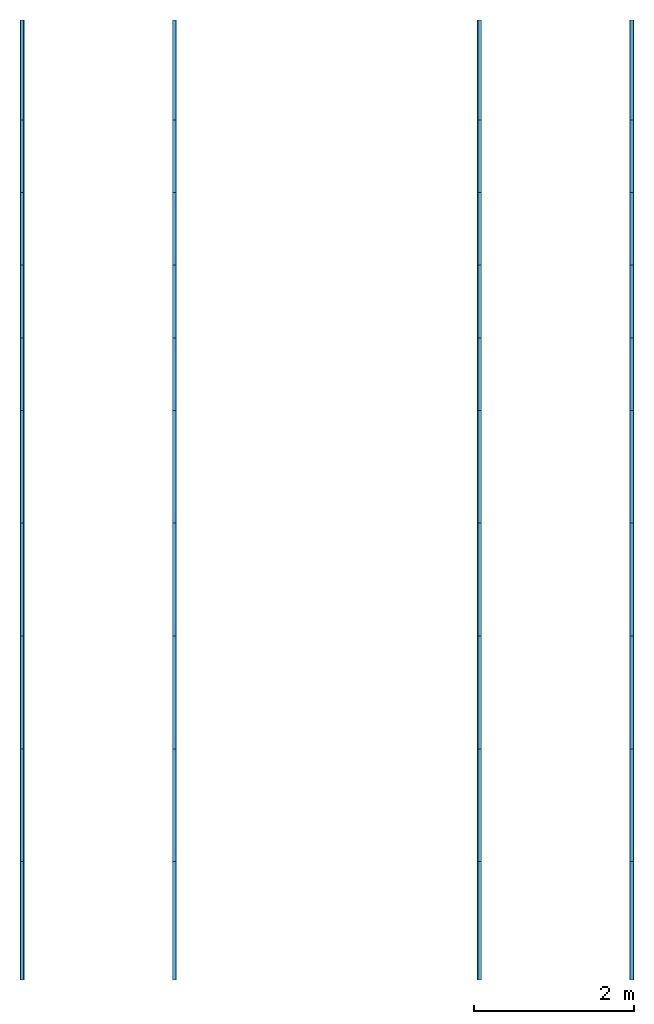
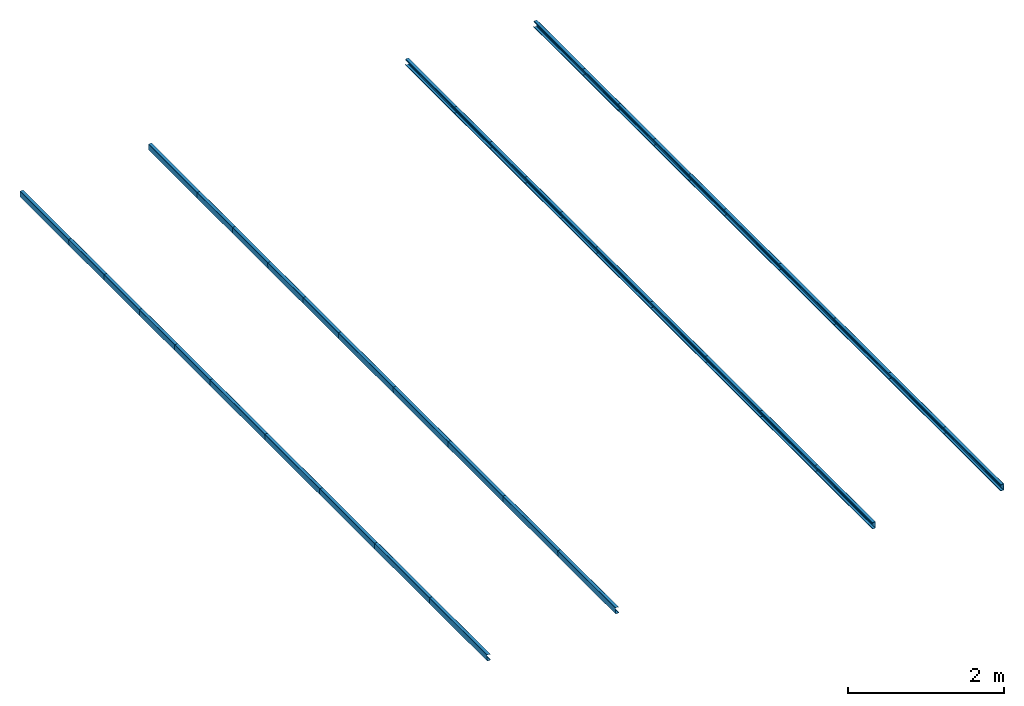
# One storey: 40 beams.
"""IFC4 building model written with IfcOpenShell, lengths in metres."""

import ifcopenshell
import ifcopenshell.guid

model = None  # the IFC model being written
_history = None  # IfcOwnerHistory: only IFC2X3 demands one
_inside = {}  # id of a spatial element -> (the spatial element, [elements in it])
_under = {}  # id of a project, library or spatial element -> (it, [spatial elements below it])
_declared = {}  # id of a project -> (the project, [libraries it declares])
_typed = {}  # id of a type object -> (the type object, [elements of that type])
_made_of = {}  # id of a material, layer set ... -> (it, [elements and type objects made of it])


def new_model(schema):
    """Start an empty IFC model of exactly this schema.

    Asked for "IFC4X3", IfcOpenShell would pick the latest addendum, in which some entities
    have other attributes; the version numbers below select the first issue.
    IFC2X3 requires an IfcOwnerHistory on every rooted entity: one is made here for all.
    """
    global model, _history
    if schema == "IFC4X3":
        model = ifcopenshell.file(schema_version=(4, 3, 0, 0))
    else:
        model = ifcopenshell.file(schema=schema)
    _inside.clear()
    _under.clear()
    _declared.clear()
    _typed.clear()
    _made_of.clear()
    _history = None
    if model.schema == "IFC2X3":
        org = make("IfcOrganization", Name="unknown")
        user = make(
            "IfcPersonAndOrganization",
            ThePerson=make("IfcPerson", FamilyName="unknown"),
            TheOrganization=org,
        )
        app = make(
            "IfcApplication",
            ApplicationDeveloper=org,
            Version="unknown",
            ApplicationFullName="unknown",
            ApplicationIdentifier="unknown",
        )
        _history = make(
            "IfcOwnerHistory",
            OwningUser=user,
            OwningApplication=app,
            ChangeAction="ADDED",
            CreationDate=0,
        )
    return model


def make(cls, **values):
    """One entity of the class cls with the attributes given. An attribute that is None is left unset."""
    return model.create_entity(
        cls, **{name: value for name, value in values.items() if value is not None}
    )


def rooted(cls, **values):
    """An entity with a GlobalId (a new one), such as an element, a storey or a relation."""
    return make(cls, GlobalId=ifcopenshell.guid.new(), OwnerHistory=_history, **values)


def si_unit(unit_type, name, prefix=None):
    """IfcSIUnit, for example si_unit("LENGTHUNIT", "METRE", prefix="MILLI")."""
    return make("IfcSIUnit", UnitType=unit_type, Prefix=prefix, Name=name)


def derived_unit(unit_type, elements):
    """IfcDerivedUnit: a product of units, each with its exponent."""
    return make(
        "IfcDerivedUnit",
        Elements=[
            make("IfcDerivedUnitElement", Unit=unit, Exponent=power)
            for unit, power in elements
        ],
        UnitType=unit_type,
    )


def assignment(units):
    """IfcUnitAssignment: the units of a project."""
    return None if units is None else make("IfcUnitAssignment", Units=units)


def point(xyz):
    """IfcCartesianPoint."""
    return None if xyz is None else make("IfcCartesianPoint", Coordinates=xyz)


def direction(xyz):
    """IfcDirection."""
    return None if xyz is None else make("IfcDirection", DirectionRatios=xyz)


def frame(location, z_axis=None, x_axis=None):
    """IfcAxis2Placement3D, a coordinate frame: its origin and axes. An axis left out is left unset."""
    return make(
        "IfcAxis2Placement3D",
        Location=point(location),
        Axis=direction(z_axis),
        RefDirection=direction(x_axis),
    )


def frame_2d(location, x_axis=None):
    """IfcAxis2Placement2D, a coordinate frame in the plane: its origin and x axis."""
    return make(
        "IfcAxis2Placement2D", Location=point(location), RefDirection=direction(x_axis)
    )


def origin_with_axes():
    """The frame at (0, 0, 0) with the z axis (0, 0, 1) and the x axis (1, 0, 0) written out."""
    return frame((0.0, 0.0, 0.0), z_axis=(0.0, 0.0, 1.0), x_axis=(1.0, 0.0, 0.0))


def origin_2d_with_axis():
    """The frame at (0, 0) in the plane with the x axis (1, 0) written out."""
    return frame_2d((0.0, 0.0), x_axis=(1.0, 0.0))


def place(relative_to, where):
    """IfcLocalPlacement: puts the frame where relative to a parent placement (None: the world)."""
    return make(
        "IfcLocalPlacement", PlacementRelTo=relative_to, RelativePlacement=where
    )


def context(
    kind, dimensions, precision=None, world=None, true_north=None, identifier=None
):
    """IfcGeometricRepresentationContext, for example the 3D "Model" context."""
    return make(
        "IfcGeometricRepresentationContext",
        ContextIdentifier=identifier,
        ContextType=kind,
        CoordinateSpaceDimension=dimensions,
        Precision=precision,
        WorldCoordinateSystem=world,
        TrueNorth=true_north,
    )


def project(units=None, contexts=None):
    """IfcProject with its units and contexts."""
    return rooted(
        "IfcProject",
        Name="project",
        RepresentationContexts=contexts,
        UnitsInContext=assignment(units),
    )


def spatial(cls, under=None, at=None, **own):
    """A site, building, storey or space (cls), placed at a placement, below another one or the project."""
    s = rooted(cls, ObjectPlacement=at, **own)
    if under is not None:
        _under.setdefault(under.id(), (under, []))[1].append(s)
    return s


def profile(cls, at=None, kind="AREA", **sizes):
    """A parametric profile (cls). Its sizes go by their IFC names, for example OverallWidth=200.0."""
    return make(cls, ProfileType=kind, Position=at, **sizes)


def c_section(**sizes):
    """IfcCShapeProfileDef."""
    return profile("IfcCShapeProfileDef", **sizes)


def extrude(swept, where, along, depth):
    """IfcExtrudedAreaSolid: the profile swept, set in the frame where, extruded along a direction by depth."""
    return make(
        "IfcExtrudedAreaSolid",
        SweptArea=swept,
        Position=where,
        ExtrudedDirection=direction(along),
        Depth=depth,
    )


def shape(context_of_items, identifier, shape_type, items):
    """IfcShapeRepresentation: the items that make up one representation, for example the "Body"."""
    return make(
        "IfcShapeRepresentation",
        ContextOfItems=context_of_items,
        RepresentationIdentifier=identifier,
        RepresentationType=shape_type,
        Items=items,
    )


def material(Name=None, Category=None):
    """IfcMaterial."""
    return make("IfcMaterial", Name=Name, Category=Category)


def material_profile(
    of_material, cross_section, Name=None, Category=None, Priority=None
):
    """IfcMaterialProfile: a cross section and its material."""
    return make(
        "IfcMaterialProfile",
        Name=Name,
        Material=of_material,
        Profile=cross_section,
        Priority=Priority,
        Category=Category,
    )


def profile_set(profiles, Name=None, composite=None):
    """IfcMaterialProfileSet."""
    return make(
        "IfcMaterialProfileSet",
        Name=Name,
        MaterialProfiles=profiles,
        CompositeProfile=composite,
    )


def profile_usage(for_profile_set, cardinal=None, extent=None):
    """IfcMaterialProfileSetUsage: how a profile set lies along its element."""
    return make(
        "IfcMaterialProfileSetUsage",
        ForProfileSet=for_profile_set,
        CardinalPoint=cardinal,
        ReferenceExtent=extent,
    )


def made_of(thing, what):
    """Note that an element or type object is made of a material, layer set ...; save() writes the relation."""
    if what is not None:
        _made_of.setdefault(what.id(), (what, []))[1].append(thing)
    return thing


def element(
    cls,
    number,
    at=None,
    inside=None,
    cuts=None,
    type_object=None,
    material=None,
    context=None,
    identifier="Body",
    shape_type=None,
    held_by="IfcProductDefinitionShape",
    body=None,
    shapes=None,
    **own,
):
    """One element of the class cls, such as IfcWall. Its Tag is "e" and its number.

    at: its placement. inside: the storey or other place that contains it. cuts: it is an
    opening in that element (IfcRelVoidsElement). A single representation is given by context,
    identifier, shape_type and body (its items); several are given by shapes. held_by: the class
    of the entity that holds the representations. save() writes the other relations.
    """
    e = rooted(cls, Tag="e%d" % number, ObjectPlacement=at, **own)
    if body is not None:
        shapes = [shape(context, identifier, shape_type, body)]
    if shapes is not None:
        e.Representation = make(held_by, Representations=shapes)
    if inside is not None:
        _inside.setdefault(inside.id(), (inside, []))[1].append(e)
    if cuts is not None:
        rooted(
            "IfcRelVoidsElement", RelatingBuildingElement=cuts, RelatedOpeningElement=e
        )
    if type_object is not None:
        _typed.setdefault(type_object.id(), (type_object, []))[1].append(e)
    return made_of(e, material)


def aggregate(whole, parts):
    """IfcRelAggregates: a whole, such as a stair, and the parts it consists of."""
    return rooted("IfcRelAggregates", RelatingObject=whole, RelatedObjects=parts)


def save(model, path):
    """Write the relations noted so far, then the file.

    IfcRelAggregates (storeys below a building ...), IfcRelContainedInSpatialStructure (elements
    in a storey), IfcRelDefinesByType, IfcRelAssociatesMaterial and IfcRelDeclares: one each for
    every whole, place, type object, material and project.
    """
    for whole, parts in _under.values():
        aggregate(whole, parts)
    for where, things in _inside.values():
        rooted(
            "IfcRelContainedInSpatialStructure",
            RelatedElements=things,
            RelatingStructure=where,
        )
    for kind, things in _typed.values():
        rooted("IfcRelDefinesByType", RelatedObjects=things, RelatingType=kind)
    for what, things in _made_of.values():
        rooted("IfcRelAssociatesMaterial", RelatedObjects=things, RelatingMaterial=what)
    for by, libraries in _declared.values():
        rooted("IfcRelDeclares", RelatingContext=by, RelatedDefinitions=libraries)
    model.write(path)


model = new_model("IFC4")

# Units and contexts
model_context = context("Model", 3, world=origin_with_axes())
ifc_project = project(units=[si_unit("LENGTHUNIT", "METRE"), si_unit("AREAUNIT", "SQUARE_METRE"), si_unit("VOLUMEUNIT", "CUBIC_METRE"), derived_unit("SECTIONMODULUSUNIT", [(si_unit("LENGTHUNIT", "METRE"), 3)]), derived_unit("MOMENTOFINERTIAUNIT", [(si_unit("LENGTHUNIT", "METRE"), 4)]), si_unit("PLANEANGLEUNIT", "RADIAN"), si_unit("TIMEUNIT", "SECOND"), si_unit("THERMODYNAMICTEMPERATUREUNIT", "DEGREE_CELSIUS"), derived_unit("THERMALEXPANSIONCOEFFICIENTUNIT", [(si_unit("THERMODYNAMICTEMPERATUREUNIT", "DEGREE_CELSIUS"), -1)])], contexts=[model_context])

# Site, building, storey
site = spatial("IfcSite", under=ifc_project, CompositionType="ELEMENT")
building = spatial("IfcBuilding", under=site, Name="Building", CompositionType="ELEMENT")
storey = spatial("IfcBuildingStorey", under=building, Name="LEVEL 5", CompositionType="ELEMENT", Elevation=9.8069)

# Beams
ifc_material = material(Name="SAE 1020")
ifc_material_profile_1 = material_profile(ifc_material, c_section(Depth=0.1, Width=0.05, WallThickness=0.003, Girth=0.017, InternalFilletRadius=0.003, at=origin_2d_with_axis()))
ifc_profile_set_1 = profile_set([ifc_material_profile_1])
ifc_profile_usage_1 = profile_usage(ifc_profile_set_1, cardinal=10)
beam_1_placement = place(None, frame((11.439599, 8.75, 9.8069), z_axis=(3.3783784e-07, 1.0, -3.0405405e-05), x_axis=(0.9992562, 8.3491316e-07, 0.038562213)))
element("IfcBeam", 1, at=beam_1_placement, inside=storey, material=ifc_profile_usage_1, Name="37", context=model_context, shape_type="SweptSolid", body=[
    extrude(c_section(Depth=0.1, Width=0.05, WallThickness=0.003, Girth=0.017, InternalFilletRadius=0.003, at=origin_2d_with_axis()), origin_with_axes(), (0.0, 0.0, 1.0), 1.48),
])
ifc_material_profile_2 = material_profile(ifc_material, c_section(Depth=0.1, Width=0.05, WallThickness=0.003, Girth=0.017, InternalFilletRadius=0.003, at=origin_2d_with_axis()))
ifc_profile_set_2 = profile_set([ifc_material_profile_2])
ifc_profile_usage_2 = profile_usage(ifc_profile_set_2, cardinal=10)
beam_2_placement = place(None, frame((11.4396, 19.5, 9.8068628), z_axis=(3.3783784e-07, 1.0, -3.0405405e-05), x_axis=(0.9992562, 8.3491316e-07, 0.038562213)))
element("IfcBeam", 2, at=beam_2_placement, inside=storey, material=ifc_profile_usage_2, Name="42", context=model_context, shape_type="SweptSolid", body=[
    extrude(c_section(Depth=0.1, Width=0.05, WallThickness=0.003, Girth=0.017, InternalFilletRadius=0.003, at=origin_2d_with_axis()), origin_with_axes(), (0.0, 0.0, 1.0), 1.25),
])
ifc_material_profile_3 = material_profile(ifc_material, c_section(Depth=0.1, Width=0.05, WallThickness=0.003, Girth=0.017, InternalFilletRadius=0.003, at=origin_2d_with_axis()))
ifc_profile_set_3 = profile_set([ifc_material_profile_3])
ifc_profile_usage_3 = profile_usage(ifc_profile_set_3, cardinal=10)
beam_3_placement = place(None, frame((13.3448, 8.75, 9.8783), z_axis=(3.3783784e-07, 1.0, -3.0405405e-05), x_axis=(0.9992562, 8.3491316e-07, 0.038562213)))
element("IfcBeam", 3, at=beam_3_placement, inside=storey, material=ifc_profile_usage_3, Name="43", context=model_context, shape_type="SweptSolid", body=[
    extrude(c_section(Depth=0.1, Width=0.05, WallThickness=0.003, Girth=0.017, InternalFilletRadius=0.003, at=origin_2d_with_axis()), origin_with_axes(), (0.0, 0.0, 1.0), 1.48),
])
ifc_material_profile_4 = material_profile(ifc_material, c_section(Depth=0.1, Width=0.05, WallThickness=0.003, Girth=0.017, InternalFilletRadius=0.003, at=origin_2d_with_axis()))
ifc_profile_set_4 = profile_set([ifc_material_profile_4])
ifc_profile_usage_4 = profile_usage(ifc_profile_set_4, cardinal=10)
beam_4_placement = place(None, frame((13.3448, 19.5, 9.8783004), z_axis=(3.3783784e-07, 1.0, -3.0405405e-05), x_axis=(0.9992562, 8.3491316e-07, 0.038562213)))
element("IfcBeam", 4, at=beam_4_placement, inside=storey, material=ifc_profile_usage_4, Name="48", context=model_context, shape_type="SweptSolid", body=[
    extrude(c_section(Depth=0.1, Width=0.05, WallThickness=0.003, Girth=0.017, InternalFilletRadius=0.003, at=origin_2d_with_axis()), origin_with_axes(), (0.0, 0.0, 1.0), 1.25),
])
ifc_material_profile_5 = material_profile(ifc_material, c_section(Depth=0.1, Width=0.05, WallThickness=0.003, Girth=0.017, InternalFilletRadius=0.003, at=origin_2d_with_axis()))
ifc_profile_set_5 = profile_set([ifc_material_profile_5])
ifc_profile_usage_5 = profile_usage(ifc_profile_set_5, cardinal=10)
beam_5_placement = place(None, frame((19.060401, 8.75, 9.8069), z_axis=(3.3783784e-07, 1.0, -3.0405405e-05), x_axis=(-0.9992562, 8.3491316e-07, 0.038562213)))
element("IfcBeam", 5, at=beam_5_placement, inside=storey, material=ifc_profile_usage_5, Name="168", context=model_context, shape_type="SweptSolid", body=[
    extrude(c_section(Depth=0.1, Width=0.05, WallThickness=0.003, Girth=0.017, InternalFilletRadius=0.003, at=origin_2d_with_axis()), origin_with_axes(), (0.0, 0.0, 1.0), 1.48),
])
ifc_material_profile_6 = material_profile(ifc_material, c_section(Depth=0.1, Width=0.05, WallThickness=0.003, Girth=0.017, InternalFilletRadius=0.003, at=origin_2d_with_axis()))
ifc_profile_set_6 = profile_set([ifc_material_profile_6])
ifc_profile_usage_6 = profile_usage(ifc_profile_set_6, cardinal=10)
beam_6_placement = place(None, frame((19.0604, 19.5, 9.8068628), z_axis=(3.3783784e-07, 1.0, -3.0405405e-05), x_axis=(-0.9992562, 8.3491316e-07, 0.038562213)))
element("IfcBeam", 6, at=beam_6_placement, inside=storey, material=ifc_profile_usage_6, Name="173", context=model_context, shape_type="SweptSolid", body=[
    extrude(c_section(Depth=0.1, Width=0.05, WallThickness=0.003, Girth=0.017, InternalFilletRadius=0.003, at=origin_2d_with_axis()), origin_with_axes(), (0.0, 0.0, 1.0), 1.25),
])
ifc_material_profile_7 = material_profile(ifc_material, c_section(Depth=0.1, Width=0.05, WallThickness=0.003, Girth=0.017, InternalFilletRadius=0.003, at=origin_2d_with_axis()))
ifc_profile_set_7 = profile_set([ifc_material_profile_7])
ifc_profile_usage_7 = profile_usage(ifc_profile_set_7, cardinal=10)
beam_7_placement = place(None, frame((17.1552, 8.75, 9.8783), z_axis=(3.3783784e-07, 1.0, -3.0405405e-05), x_axis=(-0.9992562, 8.3491316e-07, 0.038562213)))
element("IfcBeam", 7, at=beam_7_placement, inside=storey, material=ifc_profile_usage_7, Name="174", context=model_context, shape_type="SweptSolid", body=[
    extrude(c_section(Depth=0.1, Width=0.05, WallThickness=0.003, Girth=0.017, InternalFilletRadius=0.003, at=origin_2d_with_axis()), origin_with_axes(), (0.0, 0.0, 1.0), 1.48),
])
ifc_material_profile_8 = material_profile(ifc_material, c_section(Depth=0.1, Width=0.05, WallThickness=0.003, Girth=0.017, InternalFilletRadius=0.003, at=origin_2d_with_axis()))
ifc_profile_set_8 = profile_set([ifc_material_profile_8])
ifc_profile_usage_8 = profile_usage(ifc_profile_set_8, cardinal=10)
beam_8_placement = place(None, frame((17.1552, 19.5, 9.8783004), z_axis=(3.3783784e-07, 1.0, -3.0405405e-05), x_axis=(-0.9992562, 8.3491316e-07, 0.038562213)))
element("IfcBeam", 8, at=beam_8_placement, inside=storey, material=ifc_profile_usage_8, Name="179", context=model_context, shape_type="SweptSolid", body=[
    extrude(c_section(Depth=0.1, Width=0.05, WallThickness=0.003, Girth=0.017, InternalFilletRadius=0.003, at=origin_2d_with_axis()), origin_with_axes(), (0.0, 0.0, 1.0), 1.25),
])
ifc_material_profile_9 = material_profile(ifc_material, c_section(Depth=0.1, Width=0.05, WallThickness=0.003, Girth=0.017, InternalFilletRadius=0.003, at=origin_2d_with_axis()))
ifc_profile_set_9 = profile_set([ifc_material_profile_9])
ifc_profile_usage_9 = profile_usage(ifc_profile_set_9, cardinal=10)
beam_9_placement = place(None, frame((11.4396, 10.23, 9.8068628), z_axis=(3.3783784e-07, 1.0, -3.0405405e-05), x_axis=(0.9992562, 8.3491316e-07, 0.038562213)))
element("IfcBeam", 9, at=beam_9_placement, inside=storey, material=ifc_profile_usage_9, Name="487", context=model_context, shape_type="SweptSolid", body=[
    extrude(c_section(Depth=0.1, Width=0.05, WallThickness=0.003, Girth=0.017, InternalFilletRadius=0.003, at=origin_2d_with_axis()), origin_with_axes(), (0.0, 0.0, 1.0), 1.41),
])
ifc_material_profile_10 = material_profile(ifc_material, c_section(Depth=0.1, Width=0.05, WallThickness=0.003, Girth=0.017, InternalFilletRadius=0.003, at=origin_2d_with_axis()))
ifc_profile_set_10 = profile_set([ifc_material_profile_10])
ifc_profile_usage_10 = profile_usage(ifc_profile_set_10, cardinal=10)
beam_10_placement = place(None, frame((11.4396, 11.64, 9.8068628), z_axis=(3.3783784e-07, 1.0, -3.0405405e-05), x_axis=(0.9992562, 8.3491316e-07, 0.038562213)))
element("IfcBeam", 10, at=beam_10_placement, inside=storey, material=ifc_profile_usage_10, Name="488", context=model_context, shape_type="SweptSolid", body=[
    extrude(c_section(Depth=0.1, Width=0.05, WallThickness=0.003, Girth=0.017, InternalFilletRadius=0.003, at=origin_2d_with_axis()), origin_with_axes(), (0.0, 0.0, 1.0), 1.41),
])
ifc_material_profile_11 = material_profile(ifc_material, c_section(Depth=0.1, Width=0.05, WallThickness=0.003, Girth=0.017, InternalFilletRadius=0.003, at=origin_2d_with_axis()))
ifc_profile_set_11 = profile_set([ifc_material_profile_11])
ifc_profile_usage_11 = profile_usage(ifc_profile_set_11, cardinal=10)
beam_11_placement = place(None, frame((11.4396, 13.05, 9.8068628), z_axis=(3.3783784e-07, 1.0, -3.0405405e-05), x_axis=(0.9992562, 8.3491316e-07, 0.038562213)))
element("IfcBeam", 11, at=beam_11_placement, inside=storey, material=ifc_profile_usage_11, Name="489", context=model_context, shape_type="SweptSolid", body=[
    extrude(c_section(Depth=0.1, Width=0.05, WallThickness=0.003, Girth=0.017, InternalFilletRadius=0.003, at=origin_2d_with_axis()), origin_with_axes(), (0.0, 0.0, 1.0), 1.41),
])
ifc_material_profile_12 = material_profile(ifc_material, c_section(Depth=0.1, Width=0.05, WallThickness=0.003, Girth=0.017, InternalFilletRadius=0.003, at=origin_2d_with_axis()))
ifc_profile_set_12 = profile_set([ifc_material_profile_12])
ifc_profile_usage_12 = profile_usage(ifc_profile_set_12, cardinal=10)
beam_12_placement = place(None, frame((11.4396, 14.46, 9.8068628), z_axis=(3.3783784e-07, 1.0, -3.0405405e-05), x_axis=(0.9992562, 8.3491316e-07, 0.038562213)))
element("IfcBeam", 12, at=beam_12_placement, inside=storey, material=ifc_profile_usage_12, Name="491", context=model_context, shape_type="SweptSolid", body=[
    extrude(c_section(Depth=0.1, Width=0.05, WallThickness=0.003, Girth=0.017, InternalFilletRadius=0.003, at=origin_2d_with_axis()), origin_with_axes(), (0.0, 0.0, 1.0), 1.41),
])
ifc_material_profile_13 = material_profile(ifc_material, c_section(Depth=0.1, Width=0.05, WallThickness=0.003, Girth=0.017, InternalFilletRadius=0.003, at=origin_2d_with_axis()))
ifc_profile_set_13 = profile_set([ifc_material_profile_13])
ifc_profile_usage_13 = profile_usage(ifc_profile_set_13, cardinal=10)
beam_13_placement = place(None, frame((11.4396, 15.87, 9.8068628), z_axis=(3.3783784e-07, 1.0, -3.0405405e-05), x_axis=(0.9992562, 8.3491316e-07, 0.038562213)))
element("IfcBeam", 13, at=beam_13_placement, inside=storey, material=ifc_profile_usage_13, Name="492", context=model_context, shape_type="SweptSolid", body=[
    extrude(c_section(Depth=0.1, Width=0.05, WallThickness=0.003, Girth=0.017, InternalFilletRadius=0.003, at=origin_2d_with_axis()), origin_with_axes(), (0.0, 0.0, 1.0), 0.9075),
])
ifc_material_profile_14 = material_profile(ifc_material, c_section(Depth=0.1, Width=0.05, WallThickness=0.003, Girth=0.017, InternalFilletRadius=0.003, at=origin_2d_with_axis()))
ifc_profile_set_14 = profile_set([ifc_material_profile_14])
ifc_profile_usage_14 = profile_usage(ifc_profile_set_14, cardinal=10)
beam_14_placement = place(None, frame((11.4396, 16.7775, 9.8068628), z_axis=(3.3783784e-07, 1.0, -3.0405405e-05), x_axis=(0.9992562, 8.3491316e-07, 0.038562213)))
element("IfcBeam", 14, at=beam_14_placement, inside=storey, material=ifc_profile_usage_14, Name="493", context=model_context, shape_type="SweptSolid", body=[
    extrude(c_section(Depth=0.1, Width=0.05, WallThickness=0.003, Girth=0.017, InternalFilletRadius=0.003, at=origin_2d_with_axis()), origin_with_axes(), (0.0, 0.0, 1.0), 0.9075),
])
ifc_material_profile_15 = material_profile(ifc_material, c_section(Depth=0.1, Width=0.05, WallThickness=0.003, Girth=0.017, InternalFilletRadius=0.003, at=origin_2d_with_axis()))
ifc_profile_set_15 = profile_set([ifc_material_profile_15])
ifc_profile_usage_15 = profile_usage(ifc_profile_set_15, cardinal=10)
beam_15_placement = place(None, frame((11.4396, 17.685, 9.8068628), z_axis=(3.3783784e-07, 1.0, -3.0405405e-05), x_axis=(0.9992562, 8.3491316e-07, 0.038562213)))
element("IfcBeam", 15, at=beam_15_placement, inside=storey, material=ifc_profile_usage_15, Name="495", context=model_context, shape_type="SweptSolid", body=[
    extrude(c_section(Depth=0.1, Width=0.05, WallThickness=0.003, Girth=0.017, InternalFilletRadius=0.003, at=origin_2d_with_axis()), origin_with_axes(), (0.0, 0.0, 1.0), 0.9075),
])
ifc_material_profile_16 = material_profile(ifc_material, c_section(Depth=0.1, Width=0.05, WallThickness=0.003, Girth=0.017, InternalFilletRadius=0.003, at=origin_2d_with_axis()))
ifc_profile_set_16 = profile_set([ifc_material_profile_16])
ifc_profile_usage_16 = profile_usage(ifc_profile_set_16, cardinal=10)
beam_16_placement = place(None, frame((11.4396, 18.5925, 9.8068628), z_axis=(3.3783784e-07, 1.0, -3.0405405e-05), x_axis=(0.9992562, 8.3491316e-07, 0.038562213)))
element("IfcBeam", 16, at=beam_16_placement, inside=storey, material=ifc_profile_usage_16, Name="496", context=model_context, shape_type="SweptSolid", body=[
    extrude(c_section(Depth=0.1, Width=0.05, WallThickness=0.003, Girth=0.017, InternalFilletRadius=0.003, at=origin_2d_with_axis()), origin_with_axes(), (0.0, 0.0, 1.0), 0.9075),
])
ifc_material_profile_17 = material_profile(ifc_material, c_section(Depth=0.1, Width=0.05, WallThickness=0.003, Girth=0.017, InternalFilletRadius=0.003, at=origin_2d_with_axis()))
ifc_profile_set_17 = profile_set([ifc_material_profile_17])
ifc_profile_usage_17 = profile_usage(ifc_profile_set_17, cardinal=10)
beam_17_placement = place(None, frame((13.3448, 10.23, 9.8783004), z_axis=(3.3783784e-07, 1.0, -3.0405405e-05), x_axis=(0.9992562, 8.3491316e-07, 0.038562213)))
element("IfcBeam", 17, at=beam_17_placement, inside=storey, material=ifc_profile_usage_17, Name="497", context=model_context, shape_type="SweptSolid", body=[
    extrude(c_section(Depth=0.1, Width=0.05, WallThickness=0.003, Girth=0.017, InternalFilletRadius=0.003, at=origin_2d_with_axis()), origin_with_axes(), (0.0, 0.0, 1.0), 1.41),
])
ifc_material_profile_18 = material_profile(ifc_material, c_section(Depth=0.1, Width=0.05, WallThickness=0.003, Girth=0.017, InternalFilletRadius=0.003, at=origin_2d_with_axis()))
ifc_profile_set_18 = profile_set([ifc_material_profile_18])
ifc_profile_usage_18 = profile_usage(ifc_profile_set_18, cardinal=10)
beam_18_placement = place(None, frame((13.3448, 11.64, 9.8783004), z_axis=(3.3783784e-07, 1.0, -3.0405405e-05), x_axis=(0.9992562, 8.3491316e-07, 0.038562213)))
element("IfcBeam", 18, at=beam_18_placement, inside=storey, material=ifc_profile_usage_18, Name="499", context=model_context, shape_type="SweptSolid", body=[
    extrude(c_section(Depth=0.1, Width=0.05, WallThickness=0.003, Girth=0.017, InternalFilletRadius=0.003, at=origin_2d_with_axis()), origin_with_axes(), (0.0, 0.0, 1.0), 1.41),
])
ifc_material_profile_19 = material_profile(ifc_material, c_section(Depth=0.1, Width=0.05, WallThickness=0.003, Girth=0.017, InternalFilletRadius=0.003, at=origin_2d_with_axis()))
ifc_profile_set_19 = profile_set([ifc_material_profile_19])
ifc_profile_usage_19 = profile_usage(ifc_profile_set_19, cardinal=10)
beam_19_placement = place(None, frame((13.3448, 13.05, 9.8783004), z_axis=(3.3783784e-07, 1.0, -3.0405405e-05), x_axis=(0.9992562, 8.3491316e-07, 0.038562213)))
element("IfcBeam", 19, at=beam_19_placement, inside=storey, material=ifc_profile_usage_19, Name="500", context=model_context, shape_type="SweptSolid", body=[
    extrude(c_section(Depth=0.1, Width=0.05, WallThickness=0.003, Girth=0.017, InternalFilletRadius=0.003, at=origin_2d_with_axis()), origin_with_axes(), (0.0, 0.0, 1.0), 1.41),
])
ifc_material_profile_20 = material_profile(ifc_material, c_section(Depth=0.1, Width=0.05, WallThickness=0.003, Girth=0.017, InternalFilletRadius=0.003, at=origin_2d_with_axis()))
ifc_profile_set_20 = profile_set([ifc_material_profile_20])
ifc_profile_usage_20 = profile_usage(ifc_profile_set_20, cardinal=10)
beam_20_placement = place(None, frame((13.3448, 14.46, 9.8783004), z_axis=(3.3783784e-07, 1.0, -3.0405405e-05), x_axis=(0.9992562, 8.3491316e-07, 0.038562213)))
element("IfcBeam", 20, at=beam_20_placement, inside=storey, material=ifc_profile_usage_20, Name="501", context=model_context, shape_type="SweptSolid", body=[
    extrude(c_section(Depth=0.1, Width=0.05, WallThickness=0.003, Girth=0.017, InternalFilletRadius=0.003, at=origin_2d_with_axis()), origin_with_axes(), (0.0, 0.0, 1.0), 1.41),
])
ifc_material_profile_21 = material_profile(ifc_material, c_section(Depth=0.1, Width=0.05, WallThickness=0.003, Girth=0.017, InternalFilletRadius=0.003, at=origin_2d_with_axis()))
ifc_profile_set_21 = profile_set([ifc_material_profile_21])
ifc_profile_usage_21 = profile_usage(ifc_profile_set_21, cardinal=10)
beam_21_placement = place(None, frame((13.3448, 15.87, 9.8783004), z_axis=(3.3783784e-07, 1.0, -3.0405405e-05), x_axis=(0.9992562, 8.3491316e-07, 0.038562213)))
element("IfcBeam", 21, at=beam_21_placement, inside=storey, material=ifc_profile_usage_21, Name="503", context=model_context, shape_type="SweptSolid", body=[
    extrude(c_section(Depth=0.1, Width=0.05, WallThickness=0.003, Girth=0.017, InternalFilletRadius=0.003, at=origin_2d_with_axis()), origin_with_axes(), (0.0, 0.0, 1.0), 0.9075),
])
ifc_material_profile_22 = material_profile(ifc_material, c_section(Depth=0.1, Width=0.05, WallThickness=0.003, Girth=0.017, InternalFilletRadius=0.003, at=origin_2d_with_axis()))
ifc_profile_set_22 = profile_set([ifc_material_profile_22])
ifc_profile_usage_22 = profile_usage(ifc_profile_set_22, cardinal=10)
beam_22_placement = place(None, frame((13.3448, 16.7775, 9.8783004), z_axis=(3.3783784e-07, 1.0, -3.0405405e-05), x_axis=(0.9992562, 8.3491316e-07, 0.038562213)))
element("IfcBeam", 22, at=beam_22_placement, inside=storey, material=ifc_profile_usage_22, Name="504", context=model_context, shape_type="SweptSolid", body=[
    extrude(c_section(Depth=0.1, Width=0.05, WallThickness=0.003, Girth=0.017, InternalFilletRadius=0.003, at=origin_2d_with_axis()), origin_with_axes(), (0.0, 0.0, 1.0), 0.9075),
])
ifc_material_profile_23 = material_profile(ifc_material, c_section(Depth=0.1, Width=0.05, WallThickness=0.003, Girth=0.017, InternalFilletRadius=0.003, at=origin_2d_with_axis()))
ifc_profile_set_23 = profile_set([ifc_material_profile_23])
ifc_profile_usage_23 = profile_usage(ifc_profile_set_23, cardinal=10)
beam_23_placement = place(None, frame((13.3448, 17.685, 9.8783004), z_axis=(3.3783784e-07, 1.0, -3.0405405e-05), x_axis=(0.9992562, 8.3491316e-07, 0.038562213)))
element("IfcBeam", 23, at=beam_23_placement, inside=storey, material=ifc_profile_usage_23, Name="505", context=model_context, shape_type="SweptSolid", body=[
    extrude(c_section(Depth=0.1, Width=0.05, WallThickness=0.003, Girth=0.017, InternalFilletRadius=0.003, at=origin_2d_with_axis()), origin_with_axes(), (0.0, 0.0, 1.0), 0.9075),
])
ifc_material_profile_24 = material_profile(ifc_material, c_section(Depth=0.1, Width=0.05, WallThickness=0.003, Girth=0.017, InternalFilletRadius=0.003, at=origin_2d_with_axis()))
ifc_profile_set_24 = profile_set([ifc_material_profile_24])
ifc_profile_usage_24 = profile_usage(ifc_profile_set_24, cardinal=10)
beam_24_placement = place(None, frame((13.3448, 18.5925, 9.8783004), z_axis=(3.3783784e-07, 1.0, -3.0405405e-05), x_axis=(0.9992562, 8.3491316e-07, 0.038562213)))
element("IfcBeam", 24, at=beam_24_placement, inside=storey, material=ifc_profile_usage_24, Name="507", context=model_context, shape_type="SweptSolid", body=[
    extrude(c_section(Depth=0.1, Width=0.05, WallThickness=0.003, Girth=0.017, InternalFilletRadius=0.003, at=origin_2d_with_axis()), origin_with_axes(), (0.0, 0.0, 1.0), 0.9075),
])
ifc_material_profile_25 = material_profile(ifc_material, c_section(Depth=0.1, Width=0.05, WallThickness=0.003, Girth=0.017, InternalFilletRadius=0.003, at=origin_2d_with_axis()))
ifc_profile_set_25 = profile_set([ifc_material_profile_25])
ifc_profile_usage_25 = profile_usage(ifc_profile_set_25, cardinal=10)
beam_25_placement = place(None, frame((19.0604, 10.23, 9.8068628), z_axis=(3.3783784e-07, 1.0, -3.0405405e-05), x_axis=(-0.9992562, 8.3491316e-07, 0.038562213)))
element("IfcBeam", 25, at=beam_25_placement, inside=storey, material=ifc_profile_usage_25, Name="995", context=model_context, shape_type="SweptSolid", body=[
    extrude(c_section(Depth=0.1, Width=0.05, WallThickness=0.003, Girth=0.017, InternalFilletRadius=0.003, at=origin_2d_with_axis()), origin_with_axes(), (0.0, 0.0, 1.0), 1.41),
])
ifc_material_profile_26 = material_profile(ifc_material, c_section(Depth=0.1, Width=0.05, WallThickness=0.003, Girth=0.017, InternalFilletRadius=0.003, at=origin_2d_with_axis()))
ifc_profile_set_26 = profile_set([ifc_material_profile_26])
ifc_profile_usage_26 = profile_usage(ifc_profile_set_26, cardinal=10)
beam_26_placement = place(None, frame((19.0604, 11.64, 9.8068628), z_axis=(3.3783784e-07, 1.0, -3.0405405e-05), x_axis=(-0.9992562, 8.3491316e-07, 0.038562213)))
element("IfcBeam", 26, at=beam_26_placement, inside=storey, material=ifc_profile_usage_26, Name="996", context=model_context, shape_type="SweptSolid", body=[
    extrude(c_section(Depth=0.1, Width=0.05, WallThickness=0.003, Girth=0.017, InternalFilletRadius=0.003, at=origin_2d_with_axis()), origin_with_axes(), (0.0, 0.0, 1.0), 1.41),
])
ifc_material_profile_27 = material_profile(ifc_material, c_section(Depth=0.1, Width=0.05, WallThickness=0.003, Girth=0.017, InternalFilletRadius=0.003, at=origin_2d_with_axis()))
ifc_profile_set_27 = profile_set([ifc_material_profile_27])
ifc_profile_usage_27 = profile_usage(ifc_profile_set_27, cardinal=10)
beam_27_placement = place(None, frame((19.0604, 13.05, 9.8068628), z_axis=(3.3783784e-07, 1.0, -3.0405405e-05), x_axis=(-0.9992562, 8.3491316e-07, 0.038562213)))
element("IfcBeam", 27, at=beam_27_placement, inside=storey, material=ifc_profile_usage_27, Name="997", context=model_context, shape_type="SweptSolid", body=[
    extrude(c_section(Depth=0.1, Width=0.05, WallThickness=0.003, Girth=0.017, InternalFilletRadius=0.003, at=origin_2d_with_axis()), origin_with_axes(), (0.0, 0.0, 1.0), 1.41),
])
ifc_material_profile_28 = material_profile(ifc_material, c_section(Depth=0.1, Width=0.05, WallThickness=0.003, Girth=0.017, InternalFilletRadius=0.003, at=origin_2d_with_axis()))
ifc_profile_set_28 = profile_set([ifc_material_profile_28])
ifc_profile_usage_28 = profile_usage(ifc_profile_set_28, cardinal=10)
beam_28_placement = place(None, frame((19.0604, 14.46, 9.8068628), z_axis=(3.3783784e-07, 1.0, -3.0405405e-05), x_axis=(-0.9992562, 8.3491316e-07, 0.038562213)))
element("IfcBeam", 28, at=beam_28_placement, inside=storey, material=ifc_profile_usage_28, Name="998", context=model_context, shape_type="SweptSolid", body=[
    extrude(c_section(Depth=0.1, Width=0.05, WallThickness=0.003, Girth=0.017, InternalFilletRadius=0.003, at=origin_2d_with_axis()), origin_with_axes(), (0.0, 0.0, 1.0), 1.41),
])
ifc_material_profile_29 = material_profile(ifc_material, c_section(Depth=0.1, Width=0.05, WallThickness=0.003, Girth=0.017, InternalFilletRadius=0.003, at=origin_2d_with_axis()))
ifc_profile_set_29 = profile_set([ifc_material_profile_29])
ifc_profile_usage_29 = profile_usage(ifc_profile_set_29, cardinal=10)
beam_29_placement = place(None, frame((19.0604, 15.87, 9.8068628), z_axis=(3.3783784e-07, 1.0, -3.0405405e-05), x_axis=(-0.9992562, 8.3491316e-07, 0.038562213)))
element("IfcBeam", 29, at=beam_29_placement, inside=storey, material=ifc_profile_usage_29, Name="999", context=model_context, shape_type="SweptSolid", body=[
    extrude(c_section(Depth=0.1, Width=0.05, WallThickness=0.003, Girth=0.017, InternalFilletRadius=0.003, at=origin_2d_with_axis()), origin_with_axes(), (0.0, 0.0, 1.0), 0.9075),
])
ifc_material_profile_30 = material_profile(ifc_material, c_section(Depth=0.1, Width=0.05, WallThickness=0.003, Girth=0.017, InternalFilletRadius=0.003, at=origin_2d_with_axis()))
ifc_profile_set_30 = profile_set([ifc_material_profile_30])
ifc_profile_usage_30 = profile_usage(ifc_profile_set_30, cardinal=10)
beam_30_placement = place(None, frame((19.0604, 16.7775, 9.8068628), z_axis=(3.3783784e-07, 1.0, -3.0405405e-05), x_axis=(-0.9992562, 8.3491316e-07, 0.038562213)))
element("IfcBeam", 30, at=beam_30_placement, inside=storey, material=ifc_profile_usage_30, Name="1000", context=model_context, shape_type="SweptSolid", body=[
    extrude(c_section(Depth=0.1, Width=0.05, WallThickness=0.003, Girth=0.017, InternalFilletRadius=0.003, at=origin_2d_with_axis()), origin_with_axes(), (0.0, 0.0, 1.0), 0.9075),
])
ifc_material_profile_31 = material_profile(ifc_material, c_section(Depth=0.1, Width=0.05, WallThickness=0.003, Girth=0.017, InternalFilletRadius=0.003, at=origin_2d_with_axis()))
ifc_profile_set_31 = profile_set([ifc_material_profile_31])
ifc_profile_usage_31 = profile_usage(ifc_profile_set_31, cardinal=10)
beam_31_placement = place(None, frame((19.0604, 17.685, 9.8068628), z_axis=(3.3783784e-07, 1.0, -3.0405405e-05), x_axis=(-0.9992562, 8.3491316e-07, 0.038562213)))
element("IfcBeam", 31, at=beam_31_placement, inside=storey, material=ifc_profile_usage_31, Name="1001", context=model_context, shape_type="SweptSolid", body=[
    extrude(c_section(Depth=0.1, Width=0.05, WallThickness=0.003, Girth=0.017, InternalFilletRadius=0.003, at=origin_2d_with_axis()), origin_with_axes(), (0.0, 0.0, 1.0), 0.9075),
])
ifc_material_profile_32 = material_profile(ifc_material, c_section(Depth=0.1, Width=0.05, WallThickness=0.003, Girth=0.017, InternalFilletRadius=0.003, at=origin_2d_with_axis()))
ifc_profile_set_32 = profile_set([ifc_material_profile_32])
ifc_profile_usage_32 = profile_usage(ifc_profile_set_32, cardinal=10)
beam_32_placement = place(None, frame((19.0604, 18.5925, 9.8068628), z_axis=(3.3783784e-07, 1.0, -3.0405405e-05), x_axis=(-0.9992562, 8.3491316e-07, 0.038562213)))
element("IfcBeam", 32, at=beam_32_placement, inside=storey, material=ifc_profile_usage_32, Name="1002", context=model_context, shape_type="SweptSolid", body=[
    extrude(c_section(Depth=0.1, Width=0.05, WallThickness=0.003, Girth=0.017, InternalFilletRadius=0.003, at=origin_2d_with_axis()), origin_with_axes(), (0.0, 0.0, 1.0), 0.9075),
])
ifc_material_profile_33 = material_profile(ifc_material, c_section(Depth=0.1, Width=0.05, WallThickness=0.003, Girth=0.017, InternalFilletRadius=0.003, at=origin_2d_with_axis()))
ifc_profile_set_33 = profile_set([ifc_material_profile_33])
ifc_profile_usage_33 = profile_usage(ifc_profile_set_33, cardinal=10)
beam_33_placement = place(None, frame((17.1552, 10.23, 9.8783004), z_axis=(3.3783784e-07, 1.0, -3.0405405e-05), x_axis=(-0.9992562, 8.3491316e-07, 0.038562213)))
element("IfcBeam", 33, at=beam_33_placement, inside=storey, material=ifc_profile_usage_33, Name="1003", context=model_context, shape_type="SweptSolid", body=[
    extrude(c_section(Depth=0.1, Width=0.05, WallThickness=0.003, Girth=0.017, InternalFilletRadius=0.003, at=origin_2d_with_axis()), origin_with_axes(), (0.0, 0.0, 1.0), 1.41),
])
ifc_material_profile_34 = material_profile(ifc_material, c_section(Depth=0.1, Width=0.05, WallThickness=0.003, Girth=0.017, InternalFilletRadius=0.003, at=origin_2d_with_axis()))
ifc_profile_set_34 = profile_set([ifc_material_profile_34])
ifc_profile_usage_34 = profile_usage(ifc_profile_set_34, cardinal=10)
beam_34_placement = place(None, frame((17.1552, 11.64, 9.8783004), z_axis=(3.3783784e-07, 1.0, -3.0405405e-05), x_axis=(-0.9992562, 8.3491316e-07, 0.038562213)))
element("IfcBeam", 34, at=beam_34_placement, inside=storey, material=ifc_profile_usage_34, Name="1004", context=model_context, shape_type="SweptSolid", body=[
    extrude(c_section(Depth=0.1, Width=0.05, WallThickness=0.003, Girth=0.017, InternalFilletRadius=0.003, at=origin_2d_with_axis()), origin_with_axes(), (0.0, 0.0, 1.0), 1.41),
])
ifc_material_profile_35 = material_profile(ifc_material, c_section(Depth=0.1, Width=0.05, WallThickness=0.003, Girth=0.017, InternalFilletRadius=0.003, at=origin_2d_with_axis()))
ifc_profile_set_35 = profile_set([ifc_material_profile_35])
ifc_profile_usage_35 = profile_usage(ifc_profile_set_35, cardinal=10)
beam_35_placement = place(None, frame((17.1552, 13.05, 9.8783004), z_axis=(3.3783784e-07, 1.0, -3.0405405e-05), x_axis=(-0.9992562, 8.3491316e-07, 0.038562213)))
element("IfcBeam", 35, at=beam_35_placement, inside=storey, material=ifc_profile_usage_35, Name="1005", context=model_context, shape_type="SweptSolid", body=[
    extrude(c_section(Depth=0.1, Width=0.05, WallThickness=0.003, Girth=0.017, InternalFilletRadius=0.003, at=origin_2d_with_axis()), origin_with_axes(), (0.0, 0.0, 1.0), 1.41),
])
ifc_material_profile_36 = material_profile(ifc_material, c_section(Depth=0.1, Width=0.05, WallThickness=0.003, Girth=0.017, InternalFilletRadius=0.003, at=origin_2d_with_axis()))
ifc_profile_set_36 = profile_set([ifc_material_profile_36])
ifc_profile_usage_36 = profile_usage(ifc_profile_set_36, cardinal=10)
beam_36_placement = place(None, frame((17.1552, 14.46, 9.8783004), z_axis=(3.3783784e-07, 1.0, -3.0405405e-05), x_axis=(-0.9992562, 8.3491316e-07, 0.038562213)))
element("IfcBeam", 36, at=beam_36_placement, inside=storey, material=ifc_profile_usage_36, Name="1006", context=model_context, shape_type="SweptSolid", body=[
    extrude(c_section(Depth=0.1, Width=0.05, WallThickness=0.003, Girth=0.017, InternalFilletRadius=0.003, at=origin_2d_with_axis()), origin_with_axes(), (0.0, 0.0, 1.0), 1.41),
])
ifc_material_profile_37 = material_profile(ifc_material, c_section(Depth=0.1, Width=0.05, WallThickness=0.003, Girth=0.017, InternalFilletRadius=0.003, at=origin_2d_with_axis()))
ifc_profile_set_37 = profile_set([ifc_material_profile_37])
ifc_profile_usage_37 = profile_usage(ifc_profile_set_37, cardinal=10)
beam_37_placement = place(None, frame((17.1552, 15.87, 9.8783004), z_axis=(3.3783784e-07, 1.0, -3.0405405e-05), x_axis=(-0.9992562, 8.3491316e-07, 0.038562213)))
element("IfcBeam", 37, at=beam_37_placement, inside=storey, material=ifc_profile_usage_37, Name="1007", context=model_context, shape_type="SweptSolid", body=[
    extrude(c_section(Depth=0.1, Width=0.05, WallThickness=0.003, Girth=0.017, InternalFilletRadius=0.003, at=origin_2d_with_axis()), origin_with_axes(), (0.0, 0.0, 1.0), 0.9075),
])
ifc_material_profile_38 = material_profile(ifc_material, c_section(Depth=0.1, Width=0.05, WallThickness=0.003, Girth=0.017, InternalFilletRadius=0.003, at=origin_2d_with_axis()))
ifc_profile_set_38 = profile_set([ifc_material_profile_38])
ifc_profile_usage_38 = profile_usage(ifc_profile_set_38, cardinal=10)
beam_38_placement = place(None, frame((17.1552, 16.7775, 9.8783004), z_axis=(3.3783784e-07, 1.0, -3.0405405e-05), x_axis=(-0.9992562, 8.3491316e-07, 0.038562213)))
element("IfcBeam", 38, at=beam_38_placement, inside=storey, material=ifc_profile_usage_38, Name="1008", context=model_context, shape_type="SweptSolid", body=[
    extrude(c_section(Depth=0.1, Width=0.05, WallThickness=0.003, Girth=0.017, InternalFilletRadius=0.003, at=origin_2d_with_axis()), origin_with_axes(), (0.0, 0.0, 1.0), 0.9075),
])
ifc_material_profile_39 = material_profile(ifc_material, c_section(Depth=0.1, Width=0.05, WallThickness=0.003, Girth=0.017, InternalFilletRadius=0.003, at=origin_2d_with_axis()))
ifc_profile_set_39 = profile_set([ifc_material_profile_39])
ifc_profile_usage_39 = profile_usage(ifc_profile_set_39, cardinal=10)
beam_39_placement = place(None, frame((17.1552, 17.685, 9.8783004), z_axis=(3.3783784e-07, 1.0, -3.0405405e-05), x_axis=(-0.9992562, 8.3491316e-07, 0.038562213)))
element("IfcBeam", 39, at=beam_39_placement, inside=storey, material=ifc_profile_usage_39, Name="1009", context=model_context, shape_type="SweptSolid", body=[
    extrude(c_section(Depth=0.1, Width=0.05, WallThickness=0.003, Girth=0.017, InternalFilletRadius=0.003, at=origin_2d_with_axis()), origin_with_axes(), (0.0, 0.0, 1.0), 0.9075),
])
ifc_material_profile_40 = material_profile(ifc_material, c_section(Depth=0.1, Width=0.05, WallThickness=0.003, Girth=0.017, InternalFilletRadius=0.003, at=origin_2d_with_axis()))
ifc_profile_set_40 = profile_set([ifc_material_profile_40])
ifc_profile_usage_40 = profile_usage(ifc_profile_set_40, cardinal=10)
beam_40_placement = place(None, frame((17.1552, 18.5925, 9.8783004), z_axis=(3.3783784e-07, 1.0, -3.0405405e-05), x_axis=(-0.9992562, 8.3491316e-07, 0.038562213)))
element("IfcBeam", 40, at=beam_40_placement, inside=storey, material=ifc_profile_usage_40, Name="1010", context=model_context, shape_type="SweptSolid", body=[
    extrude(c_section(Depth=0.1, Width=0.05, WallThickness=0.003, Girth=0.017, InternalFilletRadius=0.003, at=origin_2d_with_axis()), origin_with_axes(), (0.0, 0.0, 1.0), 0.9075),
])

save(model, "model.ifc")
